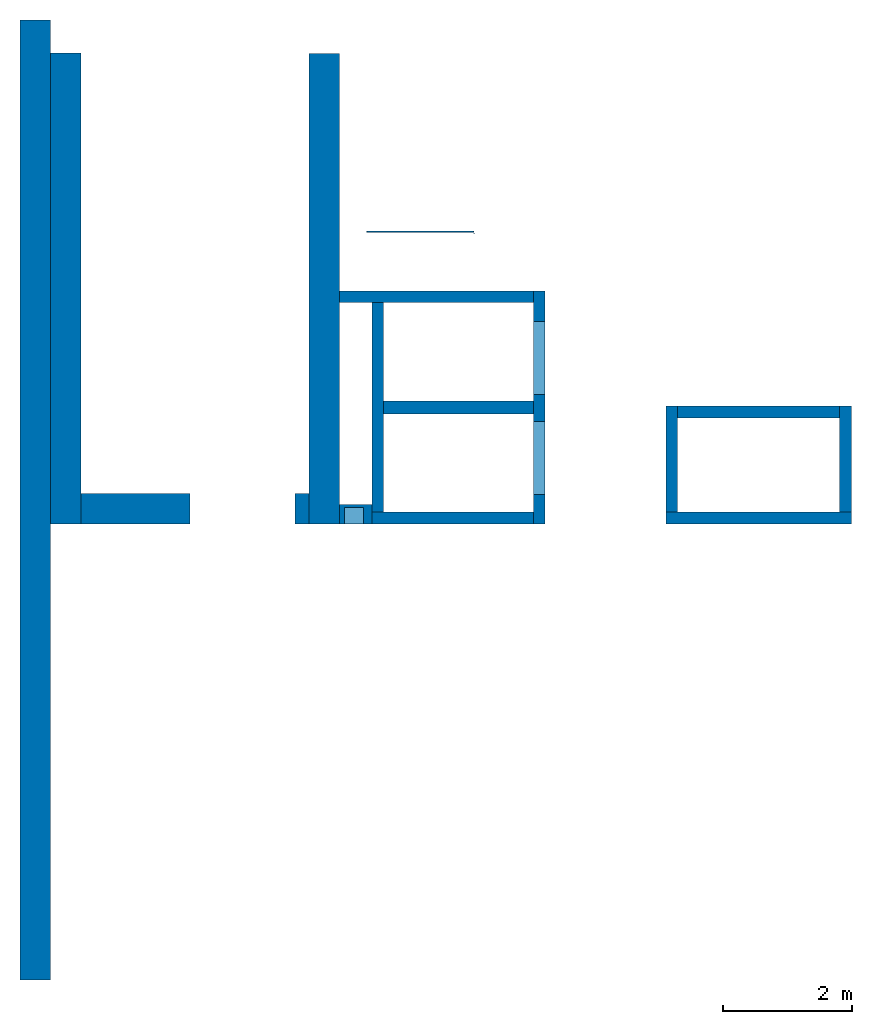
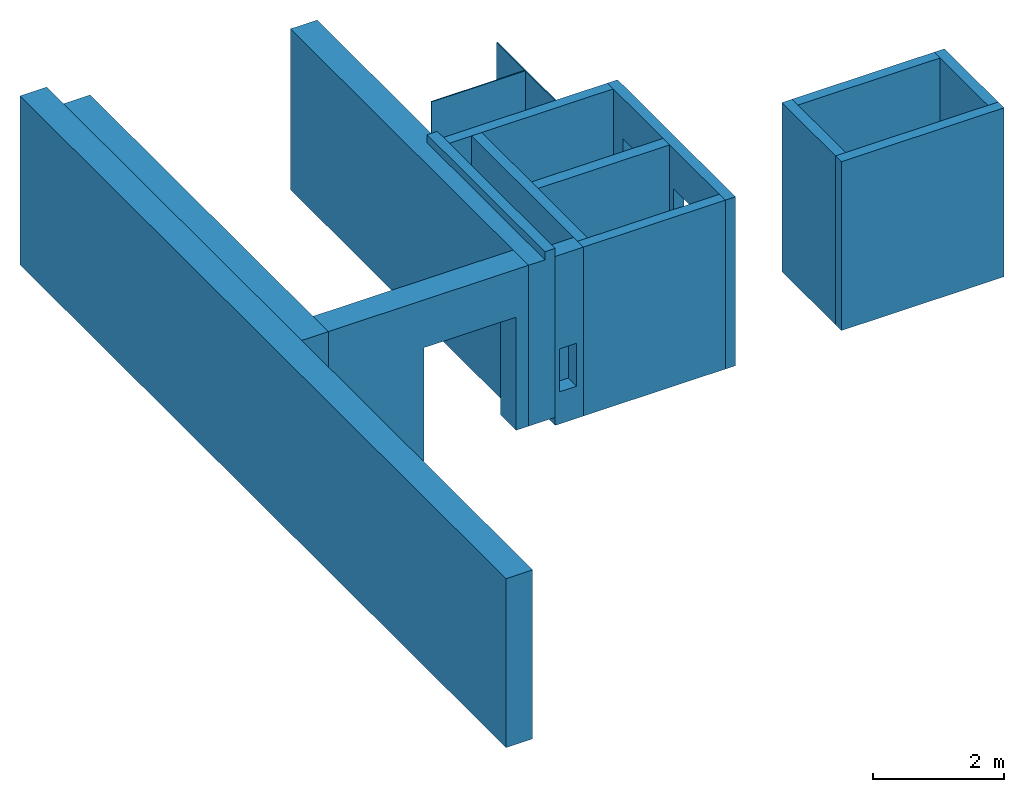
# One storey: 16 walls, 6 openings.
"""IFC4 building model written with IfcOpenShell, lengths in metres."""

from ifc_helpers import new_model, entity, si_unit, converted_unit, derived_unit, direction, frame, origin_with_axes, place, context, subcontext, project, spatial, polygons, material, type_object, element, save


model = new_model("IFC4")

# Units and contexts
model_context = context("Model", 3, precision=1e-05, world=origin_with_axes(), true_north=direction((0.0, 1.0)))
body_context = subcontext(model_context, "Body", "Model", "MODEL_VIEW")
ifc_project = project(units=[si_unit("LENGTHUNIT", "METRE"), si_unit("AREAUNIT", "SQUARE_METRE"), si_unit("VOLUMEUNIT", "CUBIC_METRE"), converted_unit("PLANEANGLEUNIT", "DEGREE", entity("IfcPlaneAngleMeasure", 0.0174532925199433), si_unit("PLANEANGLEUNIT", "RADIAN"), dimensions=[0, 0, 0, 0, 0, 0, 0]), converted_unit("TIMEUNIT", "Year", entity("IfcTimeMeasure", 31557600.0), si_unit("TIMEUNIT", "SECOND"), dimensions=[0, 0, 1, 0, 0, 0, 0]), si_unit("MASSUNIT", "GRAM", prefix="KILO"), si_unit("THERMODYNAMICTEMPERATUREUNIT", "DEGREE_CELSIUS"), si_unit("LUMINOUSINTENSITYUNIT", "LUMEN"), si_unit("ENERGYUNIT", "JOULE", prefix="MEGA"), derived_unit("THERMALCONDUCTANCEUNIT", [(si_unit("POWERUNIT", "WATT"), 1), (si_unit("LENGTHUNIT", "METRE"), -1), (si_unit("THERMODYNAMICTEMPERATUREUNIT", "KELVIN"), -1)]), derived_unit("SPECIFICHEATCAPACITYUNIT", [(si_unit("ENERGYUNIT", "JOULE"), 1), (si_unit("MASSUNIT", "GRAM", prefix="KILO"), -1), (si_unit("THERMODYNAMICTEMPERATUREUNIT", "KELVIN"), -1)]), derived_unit("MASSDENSITYUNIT", [(si_unit("MASSUNIT", "GRAM", prefix="KILO"), 1), (si_unit("VOLUMEUNIT", "CUBIC_METRE"), -1)])], contexts=[model_context])

# Site, building, storey
site_placement = place(None, origin_with_axes())
site = spatial("IfcSite", under=ifc_project, at=site_placement, CompositionType="ELEMENT")
building_placement = place(None, origin_with_axes())
building = spatial("IfcBuilding", under=site, at=building_placement, CompositionType="ELEMENT")
storey_placement = place(None, frame((0.0, 0.0, 10.5), z_axis=(0.0, 0.0, 1.0), x_axis=(1.0, 0.0, 0.0)))
storey = spatial("IfcBuildingStorey", under=building, at=storey_placement, Name="3 OG", CompositionType="ELEMENT", Elevation=10.5)

# Walls
ifc_material_1 = material(Name="Stahlbeton")
wall_type_1 = type_object("IfcWallType", Name="Stahlbeton 180", PredefinedType="NOTDEFINED")
wall_1_placement = place(None, frame((33.505, 7.05499994546756, 10.35), z_axis=(0.0, 0.0, 1.0), x_axis=(0.0, 1.0, 0.0)))
element("IfcWall", 1, at=wall_1_placement, inside=storey, type_object=wall_type_1, material=ifc_material_1, Name="Wand-001", PredefinedType="NOTDEFINED", context=body_context, shape_type="Tessellation", body=[
    polygons([(1.818, 0.0, 3.15), (0.180000000000001, 0.0, 3.15), (0.180000000000001, -0.18, 3.15), (1.818, -0.18, 3.15), (0.180000000000001, 0.0, 0.0), (0.180000000000001, 0.0, 0.15), (1.818, 0.0, 0.15), (1.818, 0.0, 0.0), (0.180000000000001, -0.18, 0.0), (1.818, -0.18, 0.0), (1.818, -0.18, 0.15)], [[[1, 2, 3, 4]], [[5, 6, 2, 1, 7, 8]], [[9, 3, 2, 6, 5]], [[4, 3, 9, 10, 11]], [[11, 7, 1, 4]], [[10, 8, 7, 11]], [[10, 9, 5, 8]]], closed=True),
])
wall_2_placement = place(None, frame((36.373, 8.87299994546756, 10.35), z_axis=(0.0, 0.0, 1.0), x_axis=(-1.0, 0.0, 0.0)))
element("IfcWall", 2, at=wall_2_placement, inside=storey, type_object=wall_type_1, material=ifc_material_1, Name="Wand-001", PredefinedType="NOTDEFINED", context=body_context, shape_type="Tessellation", body=[
    polygons([(2.688, 0.18, 3.15), (0.18, 0.18, 3.15), (0.18, 0.0, 3.15), (2.688, 0.0, 3.15), (0.18, 0.18, 0.0), (2.688, 0.18, 0.0), (0.18, 0.0, 0.0), (0.18, 0.0, 0.15), (2.688, 0.0, 0.0), (2.688, 0.0, 0.15)], [[[1, 2, 3, 4]], [[5, 2, 1, 6]], [[7, 8, 3, 2, 5]], [[4, 3, 8, 7, 9, 10]], [[6, 1, 4, 10, 9]], [[9, 7, 5, 6]]], closed=True),
])
wall_3_placement = place(None, frame((29.138, 7.05499994546755, 10.35), z_axis=(0.0, 0.0, 1.0), x_axis=(0.0, 1.0, 0.0)))
element("IfcWall", 3, at=wall_3_placement, inside=storey, type_object=wall_type_1, material=ifc_material_1, Name="Wand-003", PredefinedType="NOTDEFINED", context=body_context, shape_type="Tessellation", body=[
    polygons([(3.42, 0.18, 3.15), (0.180000000000001, 0.18, 3.15), (0.180000000000001, 0.0, 3.15), (3.42, 0.0, 3.15), (0.18, 0.18, 0.0), (0.18, 0.18, 0.15), (3.42, 0.18, 0.0), (0.18, 0.0, 0.0), (3.42, 0.0, 0.0)], [[[1, 2, 3, 4]], [[5, 6, 2, 1, 7]], [[8, 3, 2, 6, 5]], [[4, 3, 8, 9]], [[7, 1, 4, 9]], [[9, 8, 5, 7]]], closed=True),
])
wall_4_placement = place(None, frame((28.958, 7.05499994546755, 10.35), z_axis=(0.0, 0.0, 1.0), x_axis=(1.0, 0.0, 0.0)))
element("IfcWall", 4, at=wall_4_placement, inside=storey, type_object=wall_type_1, material=ifc_material_1, Name="Wand-001", PredefinedType="NOTDEFINED", context=body_context, shape_type="Tessellation", body=[
    polygons([(0.0, 0.0, 3.15), (2.5, 0.0, 3.15), (2.5, 0.180000000000001, 3.15), (0.0, 0.180000000000001, 3.15), (2.5, 0.0, 0.0), (2.5, 0.0, 0.15), (0.0, 0.0, 0.0), (2.5, 0.180000000000001, 0.0), (0.0, 0.18, 0.0)], [[[1, 2, 3, 4]], [[5, 6, 2, 1, 7]], [[8, 3, 2, 6, 5]], [[4, 3, 8, 9]], [[7, 1, 4, 9]], [[9, 8, 5, 7]]], closed=True),
])
wall_5_placement = place(None, frame((33.505, 7.05499994546756, 10.35), z_axis=(0.0, 0.0, 1.0), x_axis=(1.0, 0.0, 0.0)))
element("IfcWall", 5, at=wall_5_placement, inside=storey, type_object=wall_type_1, material=ifc_material_1, Name="Wand-001", PredefinedType="NOTDEFINED", context=body_context, shape_type="Tessellation", body=[
    polygons([(0.0, 0.180000000000001, 3.15), (0.0, 0.0, 3.15), (2.868, 0.0, 3.15), (2.868, 0.180000000000001, 3.15), (0.0, 0.180000000000001, 0.15), (0.0, 0.0, 0.15), (0.0, 0.0, 0.0), (2.868, 0.0, -5.96045879319718e-10), (2.868, 0.0, 0.15), (2.868, 0.180000000000001, 0.15), (2.868, 0.180000000000001, -5.96045879319718e-10), (0.0, 0.18, 0.0)], [[[1, 2, 3, 4]], [[5, 6, 2, 1]], [[7, 8, 9, 3, 2, 6]], [[3, 9, 10, 4]], [[5, 1, 4, 10, 11, 12]], [[12, 7, 6, 5]], [[7, 12, 11, 8]], [[8, 11, 10, 9]]], closed=True),
])
wall_6_placement = place(None, frame((31.638, 10.6549999454676, 10.35), z_axis=(0.0, 0.0, 1.0), x_axis=(-1.0, 0.0, 0.0)))
element("IfcWall", 6, at=wall_6_placement, inside=storey, type_object=wall_type_1, material=ifc_material_1, Name="Wand-003", PredefinedType="NOTDEFINED", context=body_context, shape_type="Tessellation", body=[
    polygons([(3.18, 0.18, 3.15), (0.179999999999996, 0.18, 3.15), (0.179999999999996, 0.0, 3.15), (3.18, 0.0, 3.15), (0.179999999999996, 0.18, 0.0), (3.18, 0.18, 0.0), (0.179999999999996, 0.0, 0.0), (0.179999999999996, 0.0, 0.15), (3.18, 0.0, 0.0)], [[[1, 2, 3, 4]], [[5, 2, 1, 6]], [[7, 8, 3, 2, 5]], [[4, 3, 8, 7, 9]], [[6, 1, 4, 9]], [[9, 7, 5, 6]]], closed=True),
])
wall_7_placement = place(None, frame((36.373, 7.05499994546756, 10.35), z_axis=(0.0, 0.0, 1.0), x_axis=(0.0, 1.0, 0.0)))
element("IfcWall", 7, at=wall_7_placement, inside=storey, type_object=wall_type_1, material=ifc_material_1, Name="Wand-001", PredefinedType="NOTDEFINED", context=body_context, shape_type="Tessellation", body=[
    polygons([(1.818, 0.18, 3.15), (0.180000000000001, 0.18, 3.15), (0.180000000000001, 0.0, 3.15), (1.818, 0.0, 3.15), (0.180000000000001, 0.18, 0.0), (1.818, 0.18, 0.15), (1.818, 0.18, 0.0), (0.180000000000001, 0.0, 0.0), (0.180000000000001, 0.0, 0.15), (1.818, 0.0, 0.0), (1.818, 0.0, 0.15)], [[[1, 2, 3, 4]], [[5, 2, 1, 6, 7]], [[8, 9, 3, 2, 5]], [[4, 3, 9, 8, 10, 11]], [[11, 6, 1, 4]], [[10, 7, 6, 11]], [[10, 8, 5, 7]]], closed=True),
])

# Wall, openings
wall_8_placement = place(None, frame((31.638, 7.05499994546755, 10.35), z_axis=(0.0, 0.0, 1.0), x_axis=(0.0, 1.0, 0.0)))
wall_8 = element("IfcWall", 8, at=wall_8_placement, inside=storey, type_object=wall_type_1, material=ifc_material_1, Name="Wand-002", PredefinedType="NOTDEFINED", context=body_context, shape_type="Tessellation", body=[
    polygons([(3.6, 0.179999999999996, 0.0), (0.0, 0.18, 0.0), (0.0, 0.18, 0.15), (0.0, 0.18, 3.15), (3.6, 0.179999999999996, 3.15), (3.6, 0.179999999999996, 0.15), (1.58, 0.18, 0.15), (1.58, 0.18, 2.4), (0.450000000000002, 0.18, 2.4), (0.450000000000002, 0.18, 0.15), (2.0, 0.179999999999996, 0.15), (3.13, 0.179999999999996, 0.15), (3.13, 0.179999999999996, 2.4), (2.0, 0.179999999999996, 2.4), (0.0, 0.0, 0.0), (3.6, 0.0, 0.0), (0.0, 0.0, 0.15), (0.0, 0.0, 3.15), (3.6, 0.0, 3.15), (3.6, 0.0, 0.15), (1.58, 0.0, 2.4), (1.58, 0.0, 0.15), (0.450000000000002, 0.0, 2.4), (0.450000000000002, 0.0, 0.15), (2.0, 0.0, 0.15), (3.13, 0.0, 0.15), (3.13, 0.0, 2.4), (2.0, 0.0, 2.4)], [[[1, 2, 3, 4, 5, 6], [7, 8, 9, 10], [11, 12, 13, 14]], [[15, 2, 1, 16]], [[17, 3, 2, 15]], [[17, 18, 4, 3]], [[4, 18, 19, 5]], [[5, 19, 20, 6]], [[6, 20, 16, 1]], [[21, 8, 7, 22]], [[23, 9, 8, 21]], [[24, 10, 9, 23]], [[22, 7, 10, 24]], [[25, 26, 12, 11]], [[26, 27, 13, 12]], [[27, 28, 14, 13]], [[28, 25, 11, 14]], [[20, 19, 18, 17, 15, 16], [23, 21, 22, 24], [25, 28, 27, 26]]], closed=True),
])
opening_1_placement = place(wall_8_placement, frame((1.015, 0.0, 0.15), z_axis=(0.0, 0.0, 1.0), x_axis=(1.0, 0.0, 0.0)))
element("IfcOpeningElement", 9, at=opening_1_placement, cuts=wall_8, context=body_context, identifier="Reference", shape_type="Tessellation", body=[
    polygons([(-0.565, -0.00100000000000122, 2.25), (-0.565, -0.00100000000000122, 0.0), (0.565, -0.00100000000000122, 0.0), (0.565, -0.00100000000000122, 2.25), (-0.565, 0.181000000000004, 2.25), (-0.565, 0.181000000000004, 0.0), (0.565000000000001, 0.181000000000004, 0.0), (0.565000000000001, 0.181000000000004, 2.25)], [[[1, 2, 3, 4]], [[5, 6, 2, 1]], [[6, 7, 3, 2]], [[7, 8, 4, 3]], [[8, 5, 1, 4]], [[7, 6, 5, 8]]], closed=True),
])
opening_2_placement = place(wall_8_placement, frame((2.565, 0.0, 0.15), z_axis=(0.0, 0.0, 1.0), x_axis=(1.0, 0.0, 0.0)))
element("IfcOpeningElement", 10, at=opening_2_placement, cuts=wall_8, context=body_context, identifier="Reference", shape_type="Tessellation", body=[
    polygons([(-0.565, -0.00100000000000478, 2.25), (-0.565, -0.00100000000000478, 0.0), (0.565, -0.00100000000000478, 0.0), (0.565, -0.00100000000000478, 2.25), (-0.564999999999998, 0.181000000000001, 2.25), (-0.564999999999998, 0.181000000000001, 0.0), (0.565000000000001, 0.181000000000001, 0.0), (0.565000000000001, 0.181000000000001, 2.25)], [[[1, 2, 3, 4]], [[5, 6, 2, 1]], [[6, 7, 3, 2]], [[7, 8, 4, 3]], [[8, 5, 1, 4]], [[7, 6, 5, 8]]], closed=True),
])

# Space
space_placement = place(None, frame((28.883, 12.4404999136732, 10.5), z_axis=(0.0, 0.0, 1.0), x_axis=(0.0, -1.0, 0.0)))
space = spatial("IfcSpace", under=storey, at=space_placement, CompositionType="ELEMENT", PredefinedType="NOTDEFINED")

# Wall
ifc_material_2 = material(Name="Kunststoff")
wall_type_2 = type_object("IfcWallType", Name="Kunststoff 20", PredefinedType="NOTDEFINED")
wall_9_placement = place(None, frame((30.553, 11.5727499295704, 10.35), z_axis=(0.0, 0.0, 1.0), x_axis=(-1.0, 0.0, 0.0)))
element("IfcWall", 11, at=wall_9_placement, inside=space, type_object=wall_type_2, material=ifc_material_2, Name="Wand-003", PredefinedType="NOTDEFINED", context=body_context, shape_type="Tessellation", body=[
    polygons([(0.0199999999999996, -0.00999999999999979, 3.15), (0.0199999999999996, 0.00999999999999979, 3.15), (0.0199999999999996, 0.00999999999999979, 0.15), (0.0199999999999996, -0.00999999999999979, 0.15), (1.67, -0.00999999999999979, 3.15), (1.67, 0.00999999999999979, 3.15), (1.67, 0.00999999999999979, 0.15), (1.67, -0.00999999999999979, 0.15)], [[[1, 2, 3, 4]], [[2, 1, 5, 6]], [[2, 6, 7, 3]], [[3, 7, 8, 4]], [[5, 1, 4, 8]], [[6, 5, 8, 7]]], closed=True),
])

# Wall, openings
wall_10_placement = place(None, frame((30.553, 10.6549999454676, 10.35), z_axis=(0.0, 0.0, 1.0), x_axis=(0.0, 1.0, 0.0)))
wall_10 = element("IfcWall", 12, at=wall_10_placement, inside=space, type_object=wall_type_2, material=ifc_material_2, Name="Wand-003", PredefinedType="NOTDEFINED", context=body_context, shape_type="Tessellation", body=[
    polygons([(0.895499968205613, 0.0, 0.15), (0.895499968205613, 0.0, 2.245), (1.78549996820561, 0.0, 2.245), (1.78549996820561, 0.0, 3.15), (0.0, 0.0, 3.15), (0.0, 0.0, 2.245), (0.890000000000001, 0.0, 2.245), (0.890000000000001, 0.0, 0.15), (0.895499968205613, 0.0199999999999996, 0.15), (0.895499968205613, 0.0199999999999996, 2.245), (1.78549996820561, 0.0199999999999996, 2.245), (1.78549996820561, 0.0199999999999996, 3.15), (0.0, 0.0199999999999996, 3.15), (0.0, 0.0199999999999996, 2.245), (0.890000000000001, 0.0199999999999996, 2.245), (0.890000000000001, 0.0199999999999996, 0.15)], [[[1, 2, 3, 4, 5, 6, 7, 8]], [[2, 1, 9, 10]], [[11, 3, 2, 10]], [[3, 11, 12, 4]], [[13, 5, 4, 12]], [[6, 5, 13, 14]], [[6, 14, 15, 7]], [[7, 15, 16, 8]], [[9, 1, 8, 16]], [[10, 9, 16, 15, 14, 13, 12, 11]]], closed=True),
])
opening_3_placement = place(wall_10_placement, frame((1.34049996820561, 0.0, 0.200000000000001), z_axis=(0.0, 0.0, 1.0), x_axis=(1.0, 0.0, 0.0)))
element("IfcOpeningElement", 13, at=opening_3_placement, cuts=wall_10, context=body_context, identifier="Reference", shape_type="Tessellation", body=[
    polygons([(0.445, 0.0210000000000008, 2.045), (0.445, 0.0210000000000008, -0.0500000000000007), (-0.445, 0.0210000000000008, -0.0500000000000007), (-0.445, 0.0210000000000008, 2.045), (0.445, -0.00100000000000122, 2.045), (0.445, -0.00100000000000122, -0.0500000000000007), (-0.445, -0.00100000000000122, -0.0500000000000007), (-0.445, -0.00100000000000122, 2.045)], [[[1, 2, 3, 4]], [[5, 6, 2, 1]], [[6, 7, 3, 2]], [[7, 8, 4, 3]], [[8, 5, 1, 4]], [[7, 6, 5, 8]]], closed=True),
])
opening_4_placement = place(wall_10_placement, frame((0.445, 0.0, 0.200000000000001), z_axis=(0.0, 0.0, 1.0), x_axis=(1.0, 0.0, 0.0)))
element("IfcOpeningElement", 14, at=opening_4_placement, cuts=wall_10, context=body_context, identifier="Reference", shape_type="Tessellation", body=[
    polygons([(0.445, 0.0210000000000008, 2.045), (0.445, 0.0210000000000008, -0.0500000000000007), (-0.445, 0.0210000000000008, -0.0500000000000007), (-0.445, 0.0210000000000008, 2.045), (0.445, -0.00100000000000122, 2.045), (0.445, -0.00100000000000122, -0.0500000000000007), (-0.445, -0.00100000000000122, -0.0500000000000007), (-0.445, -0.00100000000000122, 2.045)], [[[1, 2, 3, 4]], [[5, 6, 2, 1]], [[6, 7, 3, 2]], [[7, 8, 4, 3]], [[8, 5, 1, 4]], [[7, 6, 5, 8]]], closed=True),
])

# Walls
wall_type_3 = type_object("IfcWallType", Name="Stahlbeton 470", PredefinedType="NOTDEFINED")
wall_11_placement = place(None, frame((23.988, 14.8459998818788, 10.35), z_axis=(0.0, 0.0, 1.0), x_axis=(0.0, -1.0, 0.0)))
element("IfcWall", 15, at=wall_11_placement, inside=storey, type_object=wall_type_3, material=ifc_material_1, Name="Wand-001", PredefinedType="NOTDEFINED", context=body_context, shape_type="Tessellation", body=[
    polygons([(0.0, -0.469999999999999, 3.15), (14.8459998818788, -0.469999999999999, 3.15), (14.8459998818788, 0.0, 3.15), (0.0, 0.0, 3.15), (0.0, -0.469999999999999, 0.0), (14.8459998818788, -0.469999999999999, 0.0), (14.8459998818788, 0.0, 0.0), (0.0, 0.0, 0.0)], [[[1, 2, 3, 4]], [[5, 6, 2, 1]], [[3, 2, 6, 7]], [[4, 3, 7, 8]], [[5, 1, 4, 8]], [[8, 7, 6, 5]]], closed=True),
])
wall_12_placement = place(None, frame((24.458, 14.3318657372406, 10.5), z_axis=(0.0, 0.0, 1.0), x_axis=(0.0, -1.0, 0.0)))
element("IfcWall", 16, at=wall_12_placement, inside=storey, type_object=wall_type_3, material=ifc_material_1, Name="Wand-001", PredefinedType="NOTDEFINED", context=body_context, shape_type="Tessellation", body=[
    polygons([(0.0, -0.469999999999999, 0.0), (0.0, -0.469999999999999, 3.0), (0.0, 0.0, 3.0), (0.0, 0.0, 0.0), (7.27686579177299, -0.470000000000002, 0.0), (7.27686579177299, -0.470000000000002, 3.0), (7.27686579177299, 0.0, 3.0), (7.27686579177299, 0.0, 0.0)], [[[1, 2, 3, 4]], [[5, 6, 2, 1]], [[6, 7, 3, 2]], [[4, 3, 7, 8]], [[4, 8, 5, 1]], [[8, 7, 6, 5]]], closed=True),
])
wall_13_placement = place(None, frame((27.988, 14.3259998818788, 10.5), z_axis=(0.0, 0.0, 1.0), x_axis=(0.0, -1.0, 0.0)))
element("IfcWall", 17, at=wall_13_placement, inside=storey, type_object=wall_type_3, material=ifc_material_1, Name="Wand-001", PredefinedType="NOTDEFINED", context=body_context, shape_type="Tessellation", body=[
    polygons([(0.0, 0.0, 0.0), (0.0, 0.0, 3.0), (0.0, 0.469999999999999, 3.0), (0.0, 0.469999999999999, 0.0), (7.27099993641123, 0.0, 3.0), (7.27099993641123, 0.0, 0.0), (7.27099993641123, 0.290000000000003, 3.0), (3.67099993641123, 0.290000000000003, 3.0), (3.67099993641123, 0.469999999999999, 3.0), (3.67099993641123, 0.469999999999999, 3.15), (7.27099993641123, 0.469999999999999, 3.15), (7.27099993641123, 0.469999999999999, 0.0), (7.27099993641123, 0.290000000000003, 3.15), (3.67099993641123, 0.290000000000003, 3.15)], [[[1, 2, 3, 4]], [[5, 2, 1, 6]], [[7, 8, 9, 3, 2, 5]], [[3, 9, 10, 11, 12, 4]], [[4, 12, 6, 1]], [[13, 7, 5, 6, 12, 11]], [[13, 14, 8, 7]], [[8, 14, 10, 9]], [[11, 10, 14, 13]]], closed=True),
])

# Wall, opening
wall_14_placement = place(None, frame((24.458, 7.52499994546755, 10.5), z_axis=(0.0, 0.0, 1.0), x_axis=(1.0, 0.0, 0.0)))
wall_14 = element("IfcWall", 18, at=wall_14_placement, inside=storey, type_object=wall_type_3, material=ifc_material_1, Name="Wand-001", PredefinedType="NOTDEFINED", context=body_context, shape_type="Tessellation", body=[
    polygons([(1.69000000000001, 0.0, 2.11), (1.69000000000001, 0.0, 0.0), (0.0, 0.0, 0.0), (0.0, 0.0, 3.0), (3.53, 0.0, 3.0), (3.53, 0.0, 0.0), (3.31, 0.0, 0.0), (3.31, 0.0, 2.11), (1.69000000000001, -0.47, 2.11), (1.69000000000001, -0.47, 0.0), (0.0, -0.47, 0.0), (0.0, -0.47, 3.0), (3.53, -0.47, 3.0), (3.53, -0.47, 0.0), (3.31, -0.47, 0.0), (3.31, -0.47, 2.11)], [[[1, 2, 3, 4, 5, 6, 7, 8]], [[2, 1, 9, 10]], [[2, 10, 11, 3]], [[12, 4, 3, 11]], [[13, 5, 4, 12]], [[5, 13, 14, 6]], [[15, 7, 6, 14]], [[8, 7, 15, 16]], [[1, 8, 16, 9]], [[16, 15, 14, 13, 12, 11, 10, 9]]], closed=True),
])
opening_5_placement = place(wall_14_placement, frame((2.5, 0.0, 0.0), z_axis=(0.0, 0.0, 1.0), x_axis=(1.0, 0.0, 0.0)))
element("IfcOpeningElement", 19, at=opening_5_placement, cuts=wall_14, context=body_context, identifier="Reference", shape_type="Tessellation", body=[
    polygons([(-0.809999999999999, -0.471, 2.11), (-0.809999999999999, -0.471, 0.0), (0.809999999999999, -0.471, 0.0), (0.809999999999999, -0.471, 2.11), (-0.809999999999999, 0.00100000000000033, 2.11), (-0.809999999999999, 0.00100000000000033, 0.0), (0.809999999999999, 0.00100000000000033, 0.0), (0.809999999999999, 0.00100000000000033, 2.11)], [[[1, 2, 3, 4]], [[5, 6, 2, 1]], [[6, 7, 3, 2]], [[7, 8, 4, 3]], [[8, 5, 1, 4]], [[7, 6, 5, 8]]], closed=True),
])

wall_type_4 = type_object("IfcWallType", Name="Stahlbeton 300", PredefinedType="NOTDEFINED")
wall_15_placement = place(None, frame((28.458, 7.05499994546755, 10.35), z_axis=(0.0, 0.0, 1.0), x_axis=(1.0, 0.0, 0.0)))
wall_15 = element("IfcWall", 20, at=wall_15_placement, inside=storey, type_object=wall_type_4, material=ifc_material_1, Name="Wand-001", PredefinedType="NOTDEFINED", context=body_context, shape_type="Tessellation", body=[
    polygons([(0.5, 0.0, 3.15), (0.0, 0.0, 3.15), (0.0, 0.0, 0.0), (0.5, 0.0, 0.0), (0.375425898351669, 0.0, 1.4), (0.375425898351669, 0.0, 0.6), (0.0754258983516713, 0.0, 0.6), (0.0754258983516713, 0.0, 1.4), (0.5, 0.3, 3.15), (0.0, 0.3, 3.15), (0.0, 0.3, 0.0), (0.5, 0.3, 0.0), (0.375425898351669, 0.25, 1.4), (0.375425898351669, 0.25, 0.6), (0.0754258983516713, 0.25, 0.6), (0.0754258983516713, 0.25, 1.4)], [[[1, 2, 3, 4], [5, 6, 7, 8]], [[9, 10, 2, 1]], [[3, 2, 10, 11]], [[4, 3, 11, 12]], [[9, 1, 4, 12]], [[13, 14, 6, 5]], [[14, 15, 7, 6]], [[15, 16, 8, 7]], [[16, 13, 5, 8]], [[12, 11, 10, 9]], [[16, 15, 14, 13]]], closed=True),
])
opening_6_placement = place(wall_15_placement, frame((-28.458, -7.05499994546755, -10.35), z_axis=(0.0, 0.0, 1.0), x_axis=(1.0, 0.0, 0.0)))
element("IfcOpeningElement", 21, at=opening_6_placement, cuts=wall_15, PredefinedType="NOTDEFINED", context=body_context, identifier="Reference", shape_type="Tessellation", body=[
    polygons([(28.5334258983517, 7.30499994546755, 10.95), (28.8334258983517, 7.30499994546755, 10.95), (28.8334258983517, 6.75499994546755, 10.95), (28.5334258983517, 6.75499994546755, 10.95), (28.5334258983517, 7.30499994546755, 11.75), (28.8334258983517, 7.30499994546755, 11.75), (28.8334258983517, 6.75499994546755, 11.75), (28.5334258983517, 6.75499994546755, 11.75)], [[[1, 2, 3, 4]], [[1, 5, 6, 2]], [[2, 6, 7, 3]], [[4, 3, 7, 8]], [[5, 1, 4, 8]], [[6, 5, 8, 7]]], closed=True),
])

# Wall
wall_type_5 = type_object("IfcWallType", Name="Stahlbeton 200", PredefinedType="NOTDEFINED")
wall_16_placement = place(None, frame((29.138, 8.85499994546755, 10.35), z_axis=(0.0, 0.0, 1.0), x_axis=(1.0, 0.0, 0.0)))
element("IfcWall", 22, at=wall_16_placement, inside=storey, type_object=wall_type_5, material=ifc_material_1, Name="Wand-001", PredefinedType="NOTDEFINED", context=body_context, shape_type="Tessellation", body=[
    polygons([(0.0, 0.0999999999999996, 0.0), (0.0, 0.0999999999999996, 3.15), (2.32, 0.0999999999999996, 3.15), (2.32, 0.0999999999999996, 0.0), (0.0, -0.0999999999999996, 0.0), (0.0, -0.0999999999999996, 3.15), (2.32, -0.0999999999999996, 3.15), (2.32, -0.0999999999999996, 0.0)], [[[1, 2, 3, 4]], [[5, 6, 2, 1]], [[3, 2, 6, 7]], [[4, 3, 7, 8]], [[8, 5, 1, 4]], [[7, 6, 5, 8]]], closed=True),
])

save(model, "model.ifc")
